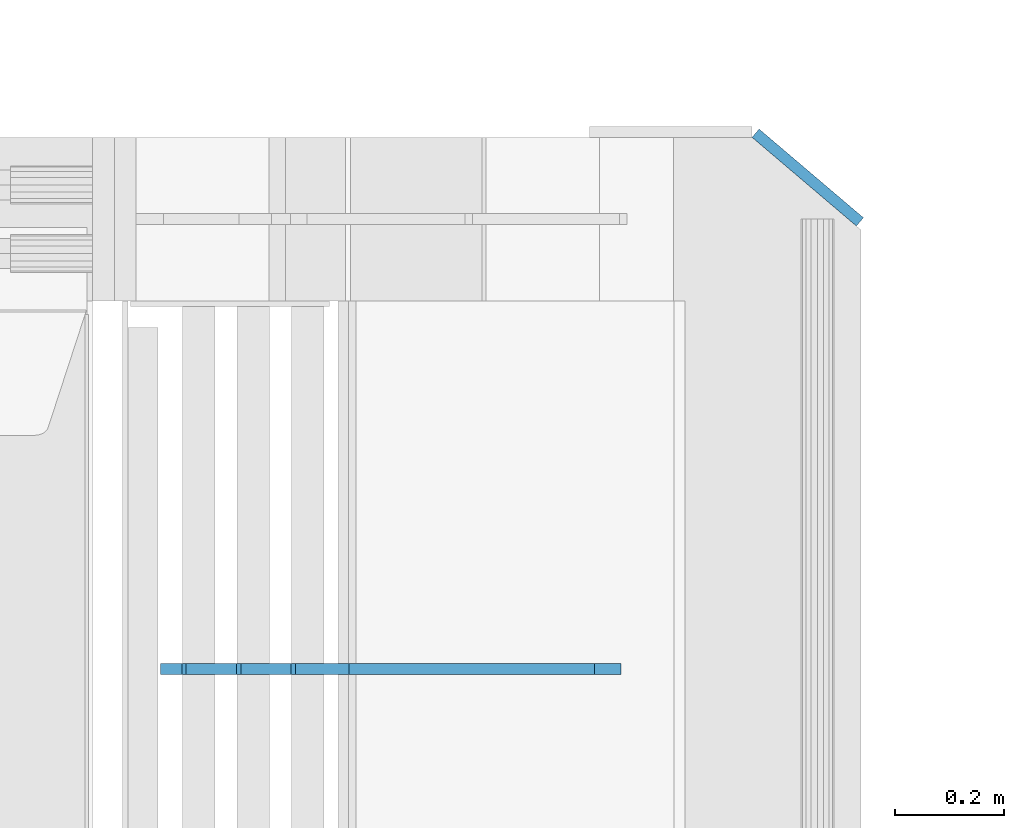
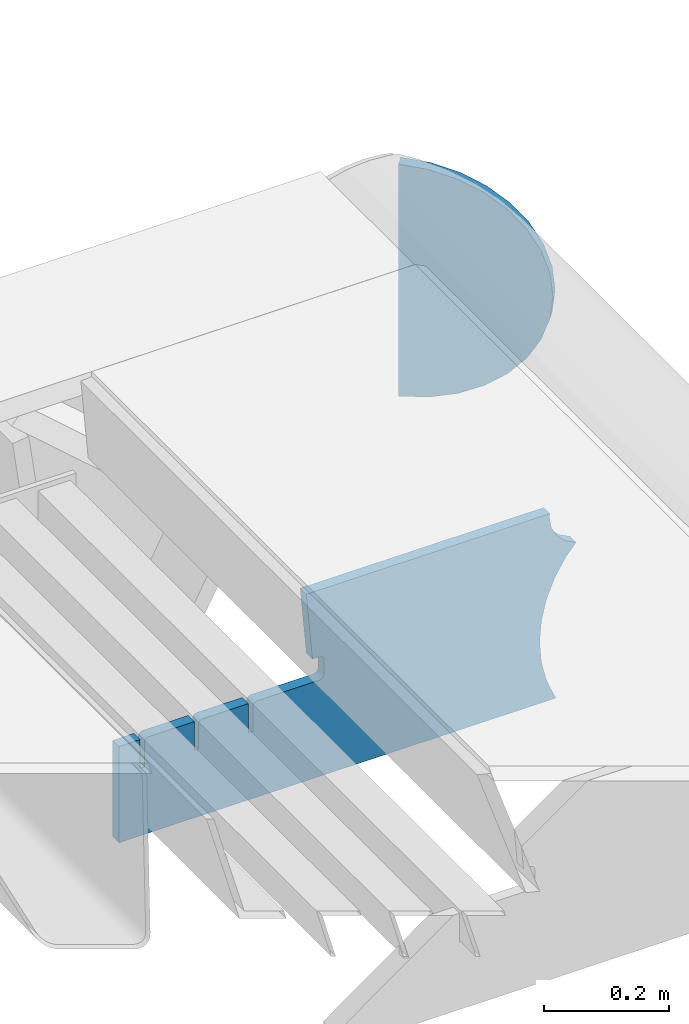
# One storey, part 244 of 257: 2 plates.
"""IFC2X3 building model written with IfcOpenShell, lengths in millimetres."""

from ifc_helpers import new_model, si_unit, frame, origin_with_axes, place, context, subcontext, project, spatial, faceted_brep, material, type_object, element, save


model = new_model("IFC2X3")

# Units and contexts
model_context = context("Model", 3, precision=1e-05, world=origin_with_axes())
body_context = subcontext(model_context, "Body", "Model", "MODEL_VIEW")
ifc_project = project(units=[si_unit("LENGTHUNIT", "METRE", prefix="MILLI"), si_unit("AREAUNIT", "SQUARE_METRE"), si_unit("VOLUMEUNIT", "CUBIC_METRE"), si_unit("MASSUNIT", "GRAM", prefix="KILO"), si_unit("TIMEUNIT", "SECOND"), si_unit("PLANEANGLEUNIT", "RADIAN"), si_unit("SOLIDANGLEUNIT", "STERADIAN"), si_unit("THERMODYNAMICTEMPERATUREUNIT", "DEGREE_CELSIUS"), si_unit("LUMINOUSINTENSITYUNIT", "LUMEN")], contexts=[model_context])

# Site, building, storey
site_placement = place(None, origin_with_axes())
site = spatial("IfcSite", under=ifc_project, at=site_placement, CompositionType="ELEMENT")
building_placement = place(site_placement, origin_with_axes())
building = spatial("IfcBuilding", under=site, at=building_placement, Name="Standard", CompositionType="ELEMENT")
storey_placement = place(building_placement, origin_with_axes())
storey = spatial("IfcBuildingStorey", under=building, at=storey_placement, Name="Undefined", CompositionType="ELEMENT", Elevation=0.0)

# Plates
ifc_material = material(Name="STEEL/S355N")
plate_type_1 = type_object("IfcPlateType", PredefinedType="NOTDEFINED")
plate_1_placement = place(storey_placement, frame((60232.9182339676, 11174.9992828369, -374.002067436516), z_axis=(0.0, 0.0, 1.0), x_axis=(-1.0, 0.0, 0.0)))
element("IfcPlate", 1, at=plate_1_placement, inside=storey, type_object=plate_type_1, material=ifc_material, context=body_context, shape_type="Brep", body=[
    faceted_brep([(801.919404066546, -10.0, 188.0), (801.919404066546, 10.0, 188.0), (801.919404066546, 10.0, 132.002067436952), (801.919404066546, -10.0, 132.002067436952), (793.919404066546, 10.0, 132.002067436952), (793.919404066546, -10.0, 132.002067436952), (793.919404066546, 10.0, 180.002067436952), (793.919404066546, -10.0, 180.002067436952), (793.52785619691, 10.0, 182.474203391951), (793.52785619691, -10.0, 182.474203391951), (792.391540021548, 10.0, 184.704349455291), (792.391540021548, -10.0, 184.704349455291), (790.621686084887, 10.0, 186.474203391951), (790.621686084887, -10.0, 186.474203391951), (788.391540021548, 10.0, 187.610519567313), (788.391540021548, -10.0, 187.610519567313), (785.919404066546, -10.0, 188.002067436952), (785.919404066546, 10.0, 188.0), (841.0, -10.0, 188.0), (841.0, -10.0, 0.0), (841.0, 10.0, 0.0), (841.0, 10.0, 188.0), (33.3619566735943, -10.0, 0.0), (33.3619566735943, 10.0, 0.0), (36.2350612208102, -10.0, 4.68848050267013), (36.2350612208102, 10.0, 4.68848050267013), (51.4877592159319, -10.0, 41.5117508652784), (51.4877592159319, 10.0, 41.5117508652784), (60.7922425881334, -10.0, 80.2677133162964), (60.7922425881334, 10.0, 80.2677133162964), (63.9194040769653, -10.0, 120.002067436515), (63.9194040769653, 10.0, 120.002067436515), (60.7922425881334, -10.0, 159.736421556734), (60.7922425881334, 10.0, 159.736421556734), (51.4877592159319, -10.0, 198.492384007752), (51.4877592159319, 10.0, 198.492384007752), (36.2350612208102, -10.0, 235.31565437036), (36.2350612208102, 10.0, 235.31565437036), (15.4097206482038, -10.0, 269.299521518803), (15.4097206482038, 10.0, 269.299521518803), (-3.35474438100209, -10.0, 291.269887256574), (-3.35474438100209, 10.0, 291.269887256574), (-2.36881039375294, -10.0000000000001, 291.426043859339), (-2.36881039375294, 10.0, 291.426043859339), (17.1449676604752, -10.0000000000001, 301.368810393754), (17.1449676604752, 10.0, 301.368810393754), (32.6311896062471, -10.0000000000001, 316.855032339527), (32.6311896062471, 10.0, 316.855032339527), (42.573956140659, -10.0000000000001, 336.368810393754), (42.573956140659, 10.0, 336.368810393754), (46.0, -10.0000000000001, 358.0), (46.0, 10.0, 358.0), (45.0495205499174, -10.0, 364.001091067617), (45.0495205499174, 10.0, 364.001091067617), (495.040008544922, -10.0, 364.010009765625), (495.040008544922, 10.0, 364.010009765625), (483.600036621094, -10.0, 233.759994506836), (483.600036621094, 10.0, 233.759994506836), (472.0, -10.0, 233.759994506836), (472.0, 10.0, 233.759994506836), (468.909830056247, -10.0, 233.270559669787), (468.909830056247, 10.0, 233.270559669787), (466.122147477072, -10.0, 231.850164450585), (466.122147477072, 10.0, 231.850164450585), (463.909830056247, -10.0, 229.637847029761), (463.909830056247, 10.0, 229.637847029761), (462.489434837051, -10.0, 226.850164450585), (462.489434837051, 10.0, 226.850164450585), (462.0, -10.0, 223.759994506836), (462.0, 10.0, 223.759994506836), (462.0, -10.0, 198.0), (462.0, 10.0, 198.0), (462.489434837051, -10.0, 194.909830056251), (462.489434837051, 10.0, 194.909830056251), (463.909830056247, -10.0, 192.122147477075), (463.909830056247, 10.0, 192.122147477075), (466.122147477072, -10.0, 189.909830056251), (466.122147477072, 10.0, 189.909830056251), (468.909830056247, -10.0, 188.489434837048), (468.909830056247, 10.0, 188.489434837048), (472.0, -10.0, 188.0), (472.0, 10.0, 188.0), (585.919404066546, -10.0, 188.002067436952), (585.919404066546, 10.0, 188.0), (588.391540021548, -10.0, 187.610519567313), (588.391540021548, 10.0, 187.610519567313), (590.621686084887, -10.0, 186.474203391951), (590.621686084887, 10.0, 186.474203391951), (592.391540021548, -10.0, 184.704349455291), (592.391540021548, 10.0, 184.704349455291), (593.52785619691, -10.0, 182.474203391951), (593.52785619691, 10.0, 182.474203391951), (593.919404066546, -10.0, 180.002067436952), (593.919404066546, 10.0, 180.002067436952), (593.919404066546, -10.0, 132.002067436952), (593.919404066546, 10.0, 132.002067436952), (601.919404066546, -10.0, 132.002067436952), (601.919404066546, 10.0, 132.002067436952), (601.919404066546, -10.0, 188.0), (601.919404066546, 10.0, 188.0), (685.919404066546, -10.0, 188.002067436952), (685.919404066546, 10.0, 188.0), (688.391540021548, -9.99999999999977, 187.610519567313), (688.391540021548, 10.0, 187.610519567313), (690.621686084887, -9.99999999999977, 186.474203391951), (690.621686084887, 10.0, 186.474203391951), (692.391540021548, -9.99999999999977, 184.704349455291), (692.391540021548, 10.0, 184.704349455291), (693.52785619691, -9.99999999999977, 182.474203391951), (693.52785619691, 10.0, 182.474203391951), (693.919404066546, -9.99999999999977, 180.002067436952), (693.919404066546, 10.0, 180.002067436952), (693.919404066546, -9.99999999999977, 132.002067436952), (693.919404066546, 10.0, 132.002067436952), (701.919404066546, -9.99999999999977, 132.002067436952), (701.919404066546, 10.0, 132.002067436952), (701.919404066546, -10.0, 188.0), (701.919404066546, 10.0, 188.0)], [[[0, 1, 2, 3]], [[3, 2, 4, 5]], [[5, 4, 6, 7]], [[7, 6, 8, 9]], [[9, 8, 10, 11]], [[11, 10, 12, 13]], [[13, 12, 14, 15]], [[16, 15, 14, 17]], [[18, 19, 20, 21]], [[20, 19, 22, 23]], [[22, 24, 25, 23]], [[26, 27, 25, 24]], [[28, 29, 27, 26]], [[30, 31, 29, 28]], [[32, 33, 31, 30]], [[34, 35, 33, 32]], [[36, 37, 35, 34]], [[38, 39, 37, 36]], [[39, 38, 40, 41]], [[40, 42, 43, 41]], [[44, 45, 43, 42]], [[46, 47, 45, 44]], [[48, 49, 47, 46]], [[50, 51, 49, 48]], [[52, 53, 51, 50]], [[54, 55, 53, 52]], [[54, 56, 57, 55]], [[56, 58, 59, 57]], [[58, 60, 61, 59]], [[60, 62, 63, 61]], [[62, 64, 65, 63]], [[64, 66, 67, 65]], [[66, 68, 69, 67]], [[68, 70, 71, 69]], [[70, 72, 73, 71]], [[72, 74, 75, 73]], [[74, 76, 77, 75]], [[76, 78, 79, 77]], [[78, 80, 81, 79]], [[81, 80, 82, 83]], [[82, 84, 85, 83]], [[86, 87, 85, 84]], [[88, 89, 87, 86]], [[90, 91, 89, 88]], [[92, 93, 91, 90]], [[94, 95, 93, 92]], [[96, 97, 95, 94]], [[98, 99, 97, 96]], [[99, 98, 100, 101]], [[100, 102, 103, 101]], [[104, 105, 103, 102]], [[106, 107, 105, 104]], [[108, 109, 107, 106]], [[110, 111, 109, 108]], [[112, 113, 111, 110]], [[114, 115, 113, 112]], [[116, 117, 115, 114]], [[117, 116, 16, 17]], [[12, 10, 8, 6, 4, 2, 1, 21, 20, 23, 25, 27, 29, 31, 33, 35, 37, 39, 41, 43, 45, 47, 49, 51, 53, 55, 57, 59, 61, 63, 65, 67, 69, 71, 73, 75, 77, 79, 81, 83, 85, 87, 89, 91, 93, 95, 97, 99, 101, 103, 105, 107, 109, 111, 113, 115, 117, 17, 14]], [[18, 21, 1, 0]], [[116, 114, 112, 110, 108, 106, 104, 102, 100, 98, 96, 94, 92, 90, 88, 86, 84, 82, 80, 78, 76, 74, 72, 70, 68, 66, 64, 62, 60, 58, 56, 54, 52, 50, 48, 46, 44, 42, 40, 38, 36, 34, 32, 30, 28, 26, 24, 22, 19, 18, 0, 3, 5, 7, 9, 11, 13, 15, 16]]]),
])
plate_type_2 = type_object("IfcPlateType", PredefinedType="NOTDEFINED")
plate_2_placement = place(storey_placement, frame((60520.6680552572, 12125.9531492057, -30.6119535183306), z_axis=(-0.0673151699806107, 0.0572188599835183, -0.996089689713064), x_axis=(-0.758954680570074, 0.645122052634529, 0.0883477789499519)))
element("IfcPlate", 2, at=plate_2_placement, inside=storey, type_object=plate_type_2, material=ifc_material, context=body_context, shape_type="Brep", body=[
    faceted_brep([(0.0, -10.0, 0.0), (-48.0501251221795, -10.0000000000073, 8.67006015777588), (-48.0501251221722, 10.0, 8.67006015777588), (0.0, 10.0, 0.0), (-93.1325836184478, -10.0, 25.6772422790527), (-93.1325836184478, 9.99999999999272, 25.6772422790532), (-133.519607544506, -10.0, 50.3672103881836), (-133.519607544513, 10.0, 50.3672103881836), (-167.65461731048, -10.0000000000073, 81.7923126220703), (-167.654617310487, 10.0, 81.7923126220703), (-194.1166534437, -10.0, 118.75399017334), (-194.1166534437, 9.99999999999272, 118.75399017334), (-212.219375612127, -10.0000000000073, 159.802307128906), (-212.219375612127, 10.0, 159.802307128906), (-220.935668947568, -10.0000000000073, 203.390228271484), (-220.935668947561, 10.0, 203.390228271484), (-220.042388918759, -10.0, 247.831420898438), (-220.042388918759, 9.99999999999272, 247.831420898438), (-209.448760989551, -10.0000000000073, 291.430206298829), (-209.448760989551, 10.0, 291.430206298828), (-189.931198123792, -10.0, 332.47769165039), (-189.931198123799, 10.0000000000073, 332.47769165039), (-161.872329716003, -10.0, 369.429595947266), (-161.872329715996, 9.99999999999272, 369.429595947266), (-126.473861698767, -10.0000000000073, 400.854248046875), (-126.473861698767, 10.0, 400.854248046875), (-85.0954742478643, -10.0, 425.544403076171), (-85.0954742478716, 10.0, 425.544403076171), (-39.3266487170476, -10.0, 442.551971435546), (-39.3266487170549, 10.0, 442.551971435546), (9.07161902882945, -10.0000000000073, 451.221954345703), (9.07161902882217, 9.99999999999272, 451.221954345703), (49.1691665649269, -10.0, 5.0931703299284e-11), (49.1691665649341, 10.0, 5.13864506501704e-11)], [[[0, 1, 2, 3]], [[1, 4, 5, 2]], [[4, 6, 7, 5]], [[6, 8, 9, 7]], [[8, 10, 11, 9]], [[10, 12, 13, 11]], [[12, 14, 15, 13]], [[14, 16, 17, 15]], [[16, 18, 19, 17]], [[18, 20, 21, 19]], [[20, 22, 23, 21]], [[22, 24, 25, 23]], [[24, 26, 27, 25]], [[26, 28, 29, 27]], [[28, 30, 31, 29]], [[30, 32, 33, 31]], [[32, 0, 3, 33]], [[5, 7, 9, 11, 13, 15, 17, 19, 21, 23, 25, 27, 29, 31, 33, 3, 2]], [[32, 30, 28, 26, 24, 22, 20, 18, 16, 14, 12, 10, 8, 6, 4, 1, 0]]]),
])

save(model, "model.ifc")
